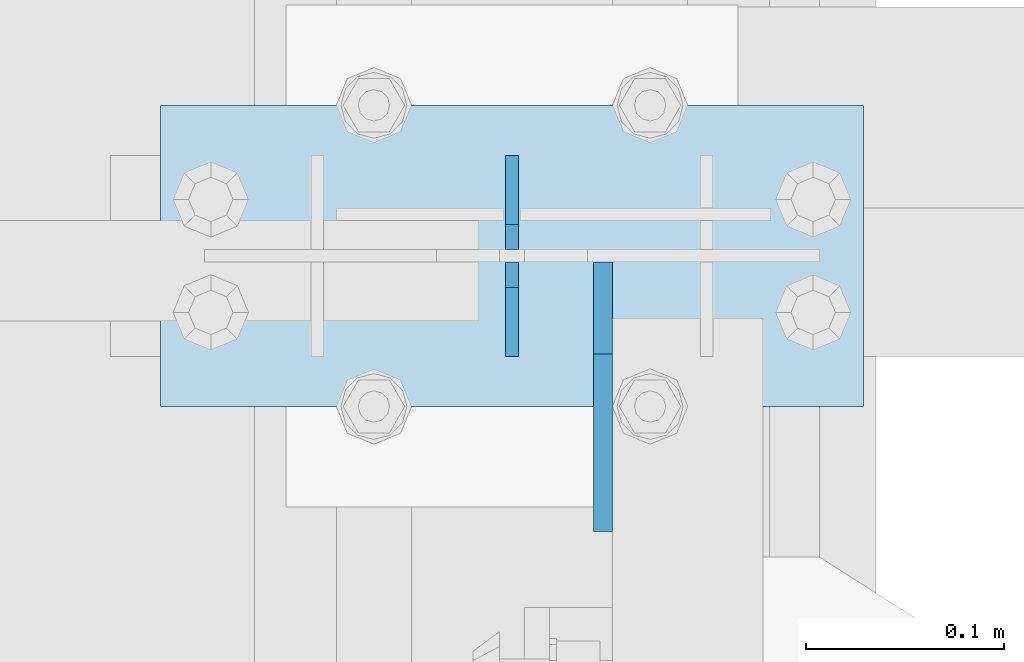
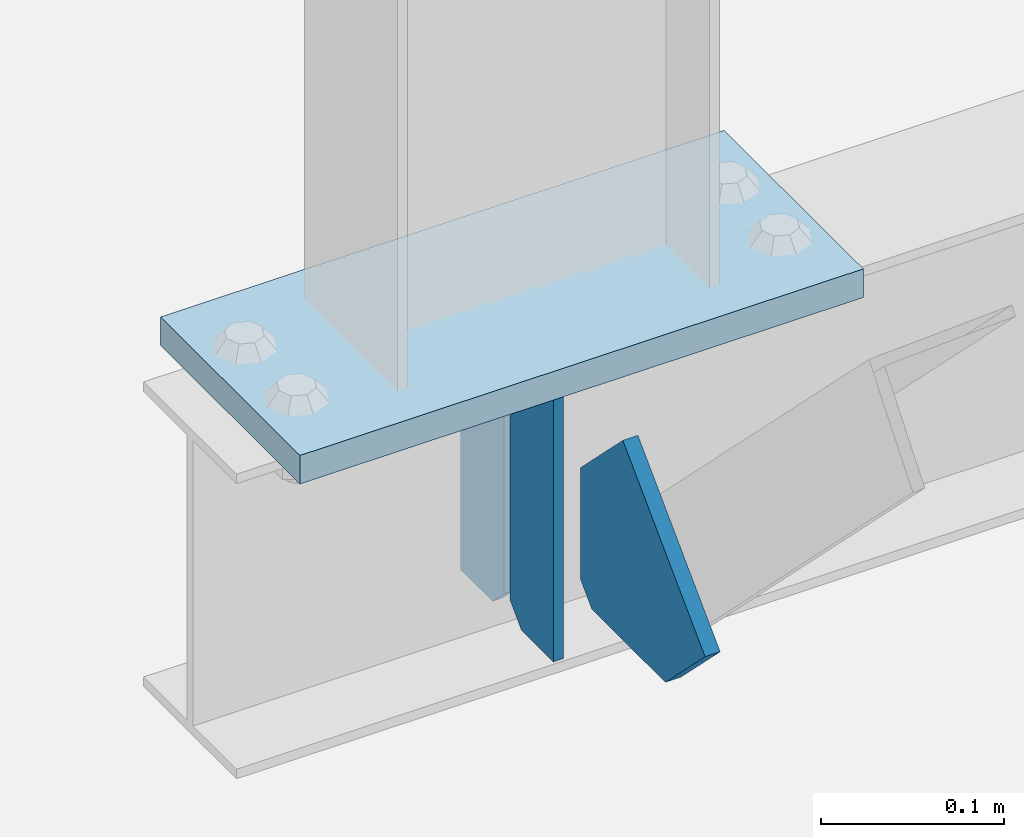
# One storey, part 3367 of 3843: 4 plates, 2 elements without a shape of their own.
"""IFC2X3 building model written with IfcOpenShell, lengths in millimetres."""

import ifcopenshell
import ifcopenshell.guid

model = None  # the IFC model being written
_history = None  # IfcOwnerHistory: only IFC2X3 demands one
_inside = {}  # id of a spatial element -> (the spatial element, [elements in it])
_under = {}  # id of a project, library or spatial element -> (it, [spatial elements below it])
_declared = {}  # id of a project -> (the project, [libraries it declares])
_typed = {}  # id of a type object -> (the type object, [elements of that type])
_made_of = {}  # id of a material, layer set ... -> (it, [elements and type objects made of it])


def new_model(schema):
    """Start an empty IFC model of exactly this schema.

    Asked for "IFC4X3", IfcOpenShell would pick the latest addendum, in which some entities
    have other attributes; the version numbers below select the first issue.
    IFC2X3 requires an IfcOwnerHistory on every rooted entity: one is made here for all.
    """
    global model, _history
    if schema == "IFC4X3":
        model = ifcopenshell.file(schema_version=(4, 3, 0, 0))
    else:
        model = ifcopenshell.file(schema=schema)
    _inside.clear()
    _under.clear()
    _declared.clear()
    _typed.clear()
    _made_of.clear()
    _history = None
    if model.schema == "IFC2X3":
        org = make("IfcOrganization", Name="unknown")
        user = make(
            "IfcPersonAndOrganization",
            ThePerson=make("IfcPerson", FamilyName="unknown"),
            TheOrganization=org,
        )
        app = make(
            "IfcApplication",
            ApplicationDeveloper=org,
            Version="unknown",
            ApplicationFullName="unknown",
            ApplicationIdentifier="unknown",
        )
        _history = make(
            "IfcOwnerHistory",
            OwningUser=user,
            OwningApplication=app,
            ChangeAction="ADDED",
            CreationDate=0,
        )
    return model


def make(cls, **values):
    """One entity of the class cls with the attributes given. An attribute that is None is left unset."""
    return model.create_entity(
        cls, **{name: value for name, value in values.items() if value is not None}
    )


def rooted(cls, **values):
    """An entity with a GlobalId (a new one), such as an element, a storey or a relation."""
    return make(cls, GlobalId=ifcopenshell.guid.new(), OwnerHistory=_history, **values)


def si_unit(unit_type, name, prefix=None):
    """IfcSIUnit, for example si_unit("LENGTHUNIT", "METRE", prefix="MILLI")."""
    return make("IfcSIUnit", UnitType=unit_type, Prefix=prefix, Name=name)


def assignment(units):
    """IfcUnitAssignment: the units of a project."""
    return None if units is None else make("IfcUnitAssignment", Units=units)


def point(xyz):
    """IfcCartesianPoint."""
    return None if xyz is None else make("IfcCartesianPoint", Coordinates=xyz)


def direction(xyz):
    """IfcDirection."""
    return None if xyz is None else make("IfcDirection", DirectionRatios=xyz)


def frame(location, z_axis=None, x_axis=None):
    """IfcAxis2Placement3D, a coordinate frame: its origin and axes. An axis left out is left unset."""
    return make(
        "IfcAxis2Placement3D",
        Location=point(location),
        Axis=direction(z_axis),
        RefDirection=direction(x_axis),
    )


def origin_with_axes():
    """The frame at (0, 0, 0) with the z axis (0, 0, 1) and the x axis (1, 0, 0) written out."""
    return frame((0.0, 0.0, 0.0), z_axis=(0.0, 0.0, 1.0), x_axis=(1.0, 0.0, 0.0))


def place(relative_to, where):
    """IfcLocalPlacement: puts the frame where relative to a parent placement (None: the world)."""
    return make(
        "IfcLocalPlacement", PlacementRelTo=relative_to, RelativePlacement=where
    )


def context(
    kind, dimensions, precision=None, world=None, true_north=None, identifier=None
):
    """IfcGeometricRepresentationContext, for example the 3D "Model" context."""
    return make(
        "IfcGeometricRepresentationContext",
        ContextIdentifier=identifier,
        ContextType=kind,
        CoordinateSpaceDimension=dimensions,
        Precision=precision,
        WorldCoordinateSystem=world,
        TrueNorth=true_north,
    )


def subcontext(parent, identifier, kind, view, scale=None):
    """IfcGeometricRepresentationSubContext, for example "Body" below "Model"."""
    return make(
        "IfcGeometricRepresentationSubContext",
        ContextIdentifier=identifier,
        ContextType=kind,
        ParentContext=parent,
        TargetScale=scale,
        TargetView=view,
    )


def project(units=None, contexts=None):
    """IfcProject with its units and contexts."""
    return rooted(
        "IfcProject",
        Name="project",
        RepresentationContexts=contexts,
        UnitsInContext=assignment(units),
    )


def spatial(cls, under=None, at=None, **own):
    """A site, building, storey or space (cls), placed at a placement, below another one or the project."""
    s = rooted(cls, ObjectPlacement=at, **own)
    if under is not None:
        _under.setdefault(under.id(), (under, []))[1].append(s)
    return s


def faces_of(points, faces, orient=None, outer=None):
    """IfcFace entities. A face is a list of loops; a loop is a list of indices into points, from 0.

    orient and outer hold one flag for each loop. By default every Orientation is true, the
    first loop of a face is its IfcFaceOuterBound and the others are IfcFaceBound.
    """
    made = []
    for i, loops in enumerate(faces):
        bounds = []
        for j, loop in enumerate(loops):
            is_outer = j == 0 if outer is None else outer[i][j]
            bounds.append(
                make(
                    "IfcFaceOuterBound" if is_outer else "IfcFaceBound",
                    Bound=make("IfcPolyLoop", Polygon=[points[k] for k in loop]),
                    Orientation=True if orient is None else orient[i][j],
                )
            )
        made.append(make("IfcFace", Bounds=bounds))
    return made


def faceted_brep(points, faces, orient=None, outer=None, voids=None):
    """IfcFacetedBrep: a solid bounded by flat faces; with voids (closed shells), ...WithVoids."""
    shared = [point(p) for p in points]
    hull = make("IfcClosedShell", CfsFaces=faces_of(shared, faces, orient, outer))
    if voids is None:
        return make("IfcFacetedBrep", Outer=hull)
    return make(
        "IfcFacetedBrepWithVoids",
        Outer=hull,
        Voids=[
            make(cls, CfsFaces=faces_of(shared, fs, o, b)) for cls, fs, o, b in voids
        ],
    )


def shape(context_of_items, identifier, shape_type, items):
    """IfcShapeRepresentation: the items that make up one representation, for example the "Body"."""
    return make(
        "IfcShapeRepresentation",
        ContextOfItems=context_of_items,
        RepresentationIdentifier=identifier,
        RepresentationType=shape_type,
        Items=items,
    )


def material(Name=None, Category=None):
    """IfcMaterial."""
    return make("IfcMaterial", Name=Name, Category=Category)


def made_of(thing, what):
    """Note that an element or type object is made of a material, layer set ...; save() writes the relation."""
    if what is not None:
        _made_of.setdefault(what.id(), (what, []))[1].append(thing)
    return thing


def type_object(cls, material=None, **own):
    """A type object (cls), such as IfcWallType, which elements share."""
    return made_of(rooted(cls, **own), material)


def element(
    cls,
    number,
    at=None,
    inside=None,
    cuts=None,
    type_object=None,
    material=None,
    context=None,
    identifier="Body",
    shape_type=None,
    held_by="IfcProductDefinitionShape",
    body=None,
    shapes=None,
    **own,
):
    """One element of the class cls, such as IfcWall. Its Tag is "e" and its number.

    at: its placement. inside: the storey or other place that contains it. cuts: it is an
    opening in that element (IfcRelVoidsElement). A single representation is given by context,
    identifier, shape_type and body (its items); several are given by shapes. held_by: the class
    of the entity that holds the representations. save() writes the other relations.
    """
    e = rooted(cls, Tag="e%d" % number, ObjectPlacement=at, **own)
    if body is not None:
        shapes = [shape(context, identifier, shape_type, body)]
    if shapes is not None:
        e.Representation = make(held_by, Representations=shapes)
    if inside is not None:
        _inside.setdefault(inside.id(), (inside, []))[1].append(e)
    if cuts is not None:
        rooted(
            "IfcRelVoidsElement", RelatingBuildingElement=cuts, RelatedOpeningElement=e
        )
    if type_object is not None:
        _typed.setdefault(type_object.id(), (type_object, []))[1].append(e)
    return made_of(e, material)


def aggregate(whole, parts):
    """IfcRelAggregates: a whole, such as a stair, and the parts it consists of."""
    return rooted("IfcRelAggregates", RelatingObject=whole, RelatedObjects=parts)


def save(model, path):
    """Write the relations noted so far, then the file.

    IfcRelAggregates (storeys below a building ...), IfcRelContainedInSpatialStructure (elements
    in a storey), IfcRelDefinesByType, IfcRelAssociatesMaterial and IfcRelDeclares: one each for
    every whole, place, type object, material and project.
    """
    for whole, parts in _under.values():
        aggregate(whole, parts)
    for where, things in _inside.values():
        rooted(
            "IfcRelContainedInSpatialStructure",
            RelatedElements=things,
            RelatingStructure=where,
        )
    for kind, things in _typed.values():
        rooted("IfcRelDefinesByType", RelatedObjects=things, RelatingType=kind)
    for what, things in _made_of.values():
        rooted("IfcRelAssociatesMaterial", RelatedObjects=things, RelatingMaterial=what)
    for by, libraries in _declared.values():
        rooted("IfcRelDeclares", RelatingContext=by, RelatedDefinitions=libraries)
    model.write(path)


model = new_model("IFC2X3")

# Units and contexts
model_context = context("Model", 3, precision=1e-05, world=origin_with_axes())
body_context = subcontext(model_context, "Body", "Model", "MODEL_VIEW")
ifc_project = project(units=[si_unit("LENGTHUNIT", "METRE", prefix="MILLI"), si_unit("AREAUNIT", "SQUARE_METRE"), si_unit("VOLUMEUNIT", "CUBIC_METRE"), si_unit("MASSUNIT", "GRAM", prefix="KILO"), si_unit("TIMEUNIT", "SECOND"), si_unit("PLANEANGLEUNIT", "RADIAN"), si_unit("SOLIDANGLEUNIT", "STERADIAN"), si_unit("THERMODYNAMICTEMPERATUREUNIT", "DEGREE_CELSIUS"), si_unit("LUMINOUSINTENSITYUNIT", "LUMEN")], contexts=[model_context])

# Site, building, storey
site_placement = place(None, origin_with_axes())
site = spatial("IfcSite", under=ifc_project, at=site_placement, CompositionType="ELEMENT")
building_placement = place(site_placement, origin_with_axes())
building = spatial("IfcBuilding", under=site, at=building_placement, Name="Undefined", CompositionType="ELEMENT")
storey_placement = place(building_placement, origin_with_axes())
storey = spatial("IfcBuildingStorey", under=building, at=storey_placement, Name="Undefined", CompositionType="ELEMENT", Elevation=0.0)

# Assembly, plates
assembly_1_placement = place(storey_placement, origin_with_axes())
assembly_1 = element("IfcElementAssembly", 1, at=assembly_1_placement, inside=storey, Name="BEAM", AssemblyPlace="NOTDEFINED", PredefinedType="RIGID_FRAME")
ifc_material = material(Name="STEEL/A572-50")
plate_type_1 = type_object("IfcPlateType", PredefinedType="NOTDEFINED")
plate_1_placement = place(assembly_1_placement, frame((36576.0000030517, 77050.9, 41495.6625), z_axis=(0.0, 0.0, -1.0), x_axis=(0.0, -1.0, 0.0)))
plate_1 = element("IfcPlate", 2, at=plate_1_placement, type_object=plate_type_1, material=ifc_material, Name="PLATE", context=body_context, shape_type="Brep", body=[
    faceted_brep([(0.0, -3.17499999999927, 0.0), (0.0, -3.17500000000291, 187.324999999997), (0.0, 3.17500000000291, 187.324999999997), (0.0, 3.17499999999927, 0.0), (34.9250001907349, -3.17500000000291, 187.324999999997), (34.9250001907349, 3.17500000000291, 187.324999999997), (47.625, -3.17500000000291, 174.625000190732), (47.625, 3.17500000000291, 174.625000190732), (47.625, -3.17499999999927, 12.6999998092651), (47.625, 3.17499999999927, 12.6999998092651), (34.9250001907349, -3.17499999999927, 0.0), (34.9250001907349, 3.17499999999927, 0.0)], [[[0, 1, 2, 3]], [[1, 4, 5, 2]], [[4, 6, 7, 5]], [[6, 8, 9, 7]], [[8, 10, 11, 9]], [[10, 0, 3, 11]], [[5, 7, 9, 11, 3, 2]], [[10, 8, 6, 4, 1, 0]]]),
])
plate_2_placement = place(assembly_1_placement, frame((36576.0000030517, 76949.3, 41495.6625), z_axis=(0.0, 0.0, -1.0), x_axis=(0.0, 1.0, 0.0)))
plate_2 = element("IfcPlate", 3, at=plate_2_placement, type_object=plate_type_1, material=ifc_material, Name="PLATE", context=body_context, shape_type="Brep", body=[
    faceted_brep([(0.0, -3.17499999999927, 0.0), (0.0, -3.17500000000291, 187.324999999997), (0.0, 3.17500000000291, 187.324999999997), (0.0, 3.17499999999927, 0.0), (34.9250001907349, -3.17500000000291, 187.324999999997), (34.9250001907349, 3.17500000000291, 187.324999999997), (47.625, -3.17500000000291, 174.625000190732), (47.625, 3.17500000000291, 174.625000190732), (47.625, -3.17499999999927, 12.6999998092651), (47.625, 3.17499999999927, 12.6999998092651), (34.9250001907349, -3.17499999999927, 0.0), (34.9250001907349, 3.17499999999927, 0.0)], [[[0, 1, 2, 3]], [[1, 4, 5, 2]], [[4, 6, 7, 5]], [[6, 8, 9, 7]], [[8, 10, 11, 9]], [[10, 0, 3, 11]], [[5, 7, 9, 11, 3, 2]], [[10, 8, 6, 4, 1, 0]]]),
])

# Assembly, plate
assembly_2_placement = place(storey_placement, origin_with_axes())
assembly_2 = element("IfcElementAssembly", 4, at=assembly_2_placement, inside=storey, Name="POST", AssemblyPlace="NOTDEFINED", PredefinedType="RIGID_FRAME")
plate_type_2 = type_object("IfcPlateType", PredefinedType="NOTDEFINED")
plate_3_placement = place(assembly_2_placement, frame((36753.8000030518, 76923.9, 41513.125), z_axis=(-1.0, 0.0, 0.0), x_axis=(0.0, 1.0, 0.0)))
plate_3 = element("IfcPlate", 5, at=plate_3_placement, type_object=plate_type_2, material=ifc_material, Name="PLATE", context=body_context, shape_type="Brep", body=[
    faceted_brep([(0.0, -9.52500000000146, 0.0), (0.0, -9.52500000000146, 355.599999999999), (0.0, 9.52500000000146, 355.599999999999), (0.0, 9.52500000000146, 0.0), (152.399999999994, -9.52500000000146, 355.599999999999), (152.399999999994, 9.52500000000146, 355.599999999999), (152.400000000001, -9.52500000000146, 0.0), (152.400000000001, 9.52500000000146, 0.0)], [[[0, 1, 2, 3]], [[1, 4, 5, 2]], [[4, 6, 7, 5]], [[6, 0, 3, 7]], [[5, 7, 3, 2]], [[6, 4, 1, 0]]]),
])
aggregate(assembly_2, [plate_3])

# Plate
plate_type_3 = type_object("IfcPlateType", PredefinedType="NOTDEFINED")
plate_4_placement = place(assembly_1_placement, frame((36622.0375, 76996.925, 41306.75), z_axis=(0.0, -1.0, 0.0), x_axis=(0.0, 0.0, 1.0)))
plate_4 = element("IfcPlate", 6, at=plate_4_placement, type_object=plate_type_3, material=ifc_material, Name="PLATE", context=body_context, shape_type="Brep", body=[
    faceted_brep([(0.0, -4.76250000000073, 12.6999998092651), (4.450703272596e-08, -4.76249999999709, 93.0710244828806), (4.450703272596e-08, 4.76249999999709, 93.0710244828806), (0.0, 4.76250000000073, 12.6999998092651), (43.3137807601452, -4.76249999999709, 136.384805065652), (43.3137807601452, 4.76249999999709, 136.384805065652), (133.209805202001, -4.76249999999709, 46.4887805392646), (133.209805202001, 4.76249999999709, 46.4887805392646), (86.7210245267561, -4.76249999999709, 0.0), (86.7210245267561, 4.76249999999709, 0.0), (12.6999998092651, -4.76250000000073, 0.0), (12.6999998092651, 4.76250000000073, 0.0)], [[[0, 1, 2, 3]], [[1, 4, 5, 2]], [[4, 6, 7, 5]], [[6, 8, 9, 7]], [[8, 10, 11, 9]], [[10, 0, 3, 11]], [[5, 7, 9, 11, 3, 2]], [[10, 8, 6, 4, 1, 0]]]),
])

aggregate(assembly_1, [plate_1, plate_2, plate_4])

save(model, "model.ifc")
